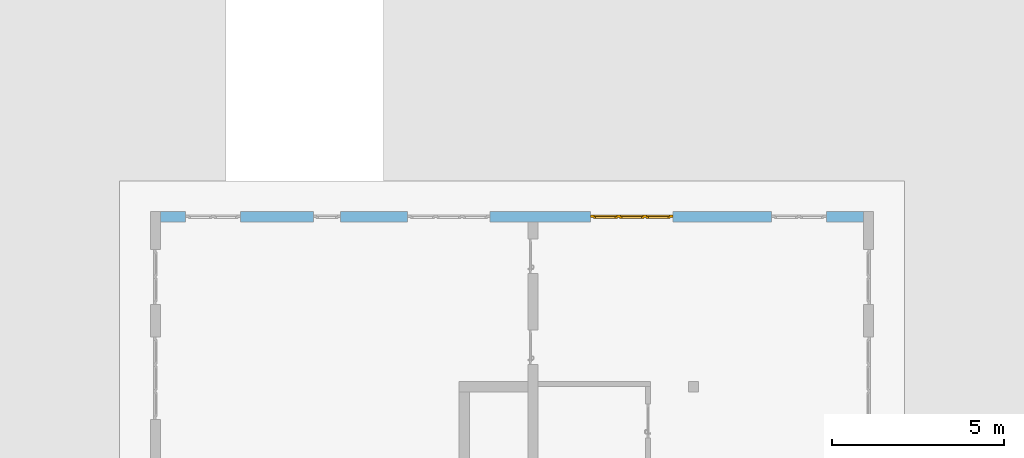
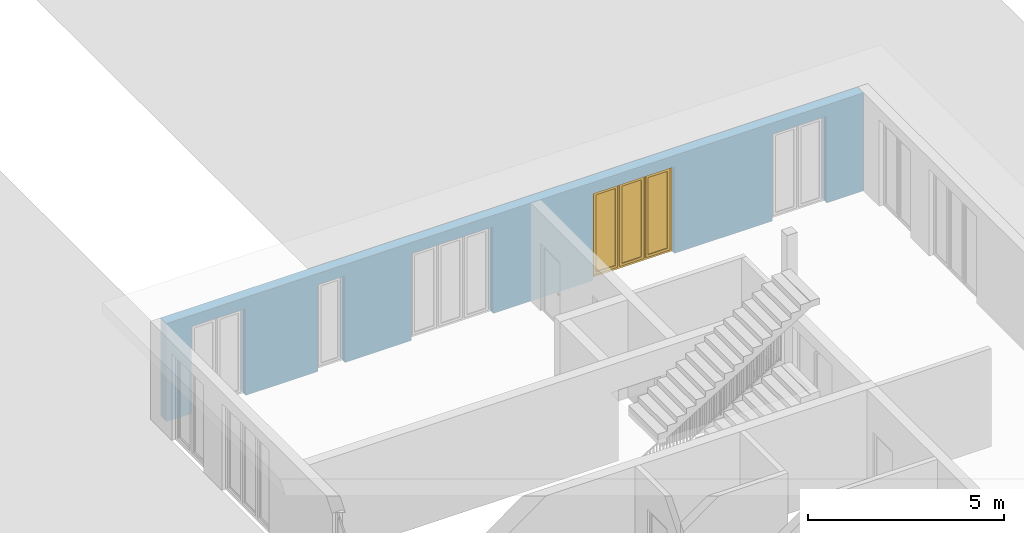
# One storey, part 17 of 23: 1 window, 5 openings, plus 1 element that does not belong to this part.
"""IFC4 building model written with IfcOpenShell, lengths in metres."""

from ifc_helpers import new_model, entity, si_unit, converted_unit, derived_unit, direction, frame, origin_with_axes, place, context, subcontext, project, spatial, polygons, source, transform, mapped, material, type_object, element, fill, save


model = new_model("IFC4")

# Units and contexts
model_context = context("Model", 3, precision=1e-05, world=origin_with_axes(), true_north=direction((0.0, 1.0)))
body_context = subcontext(model_context, "Body", "Model", "MODEL_VIEW")
ifc_project = project(units=[si_unit("LENGTHUNIT", "METRE"), si_unit("AREAUNIT", "SQUARE_METRE"), si_unit("VOLUMEUNIT", "CUBIC_METRE"), converted_unit("PLANEANGLEUNIT", "DEGREE", entity("IfcPlaneAngleMeasure", 0.0174532925199), si_unit("PLANEANGLEUNIT", "RADIAN"), dimensions=[0, 0, 0, 0, 0, 0, 0]), converted_unit("TIMEUNIT", "Year", entity("IfcTimeMeasure", 31556926.0), si_unit("TIMEUNIT", "SECOND"), dimensions=[0, 0, 1, 0, 0, 0, 0]), si_unit("MASSUNIT", "GRAM", prefix="KILO"), si_unit("THERMODYNAMICTEMPERATUREUNIT", "DEGREE_CELSIUS"), si_unit("LUMINOUSINTENSITYUNIT", "LUMEN"), si_unit("ENERGYUNIT", "JOULE", prefix="MEGA"), derived_unit("THERMALCONDUCTANCEUNIT", [(si_unit("POWERUNIT", "WATT"), 1), (si_unit("LENGTHUNIT", "METRE"), -1), (si_unit("THERMODYNAMICTEMPERATUREUNIT", "KELVIN"), -1)]), derived_unit("SPECIFICHEATCAPACITYUNIT", [(si_unit("ENERGYUNIT", "JOULE"), 1), (si_unit("MASSUNIT", "GRAM", prefix="KILO"), -1), (si_unit("THERMODYNAMICTEMPERATUREUNIT", "KELVIN"), -1)]), derived_unit("MASSDENSITYUNIT", [(si_unit("MASSUNIT", "GRAM", prefix="KILO"), 1), (si_unit("VOLUMEUNIT", "CUBIC_METRE"), -1)])], contexts=[model_context])

# Site, building, storey
site_placement = place(None, origin_with_axes())
site = spatial("IfcSite", under=ifc_project, at=site_placement, CompositionType="ELEMENT")
building_placement = place(site_placement, origin_with_axes())
building = spatial("IfcBuilding", under=site, at=building_placement, CompositionType="ELEMENT")
storey_placement = place(building_placement, origin_with_axes())
storey = spatial("IfcBuildingStorey", under=building, at=storey_placement, Name="0. Geschoss", CompositionType="ELEMENT", Elevation=0.0)

# Wall, openings, window
ifc_material = material()
wall_type = type_object("IfcWallType", Name="300", PredefinedType="NOTDEFINED")
wall_placement = place(storey_placement, frame((-11.7421993804, 8.92118776896, 0.0), z_axis=(0.0, 0.0, 1.0), x_axis=(1.0, 0.0, 0.0)))
wall = element("IfcWall", 1, at=wall_placement, inside=storey, type_object=wall_type, material=ifc_material, Name="Wand-001", PredefinedType="NOTDEFINED", context=body_context, shape_type="Tessellation", body=[
    polygons([(15.23, -0.1, 0.0), (15.23, -0.3, 0.0), (15.23, -0.3, 2.7), (15.23, 0.0, 2.7), (15.23, 0.0, 0.0), (18.102139809, 0.0, 0.0), (18.102139809, -0.3, 0.0), (18.102139809, -0.3, 2.7), (19.702139809, -0.3, 2.7), (19.702139809, -0.3, 0.0), (20.78, -0.3, 0.0), (20.78, -0.3, 3.05), (0.3, -0.3, 3.05), (0.3, -0.3, 0.0), (1.0288518641, -0.3, 0.0), (1.0288518641, -0.3, 2.7), (2.6288518641, -0.3, 2.7), (2.6288518641, -0.3, 0.0), (4.75, -0.3, 0.0), (4.75, -0.3, 2.7), (5.55, -0.3, 2.7), (5.55, -0.3, 0.0), (7.50089858046, -0.3, 0.0), (7.50089858046, -0.3, 2.7), (9.90089858046, -0.3, 2.7), (9.90089858046, -0.3, 0.0), (12.83, -0.3, 0.0), (12.83, -0.3, 2.7), (12.83, 0.0, 2.7), (12.83, 0.0, 0.0), (9.90089858046, 0.0, 0.0), (9.90089858046, 0.0, 2.7), (7.50089858046, 0.0, 2.7), (7.50089858046, 0.0, 0.0), (5.55, 0.0, 0.0), (5.55, 0.0, 2.7), (4.75, 0.0, 2.7), (4.75, 0.0, 0.0), (2.6288518641, 0.0, 0.0), (2.6288518641, 0.0, 2.7), (1.0288518641, 0.0, 2.7), (1.0288518641, 0.0, 0.0), (0.3, 0.0, 0.0), (0.3, 0.0, 3.05), (20.78, 0.0, 3.05), (20.78, 0.0, 0.0), (19.702139809, 0.0, 0.0), (19.702139809, 0.0, 2.7), (18.102139809, 0.0, 2.7), (12.83, -0.1, 0.0)], [[[1, 2, 3, 4, 5]], [[2, 1, 5, 6, 7]], [[3, 2, 7, 8, 9, 10, 11, 12, 13, 14, 15, 16, 17, 18, 19, 20, 21, 22, 23, 24, 25, 26, 27, 28]], [[4, 3, 28, 29]], [[6, 5, 4, 29, 30, 31, 32, 33, 34, 35, 36, 37, 38, 39, 40, 41, 42, 43, 44, 45, 46, 47, 48, 49]], [[6, 49, 8, 7]], [[8, 49, 48, 9]], [[48, 47, 10, 9]], [[46, 11, 10, 47]], [[12, 11, 46, 45]], [[45, 44, 13, 12]], [[44, 43, 14, 13]], [[15, 14, 43, 42]], [[16, 15, 42, 41]], [[40, 17, 16, 41]], [[18, 17, 40, 39]], [[19, 18, 39, 38]], [[20, 19, 38, 37]], [[36, 21, 20, 37]], [[22, 21, 36, 35]], [[22, 35, 34, 23]], [[34, 33, 24, 23]], [[24, 33, 32, 25]], [[32, 31, 26, 25]], [[50, 27, 26, 31, 30]], [[28, 27, 50, 30, 29]]], closed=True),
])
opening_1_placement = place(wall_placement, frame((1.8288518641, 0.0, 0.0), z_axis=(0.0, 0.0, 1.0), x_axis=(1.0, 0.0, 0.0)))
element("IfcOpeningElement", 2, at=opening_1_placement, cuts=wall, Name="Fenster-001", context=body_context, identifier="Reference", shape_type="Tessellation", body=[
    polygons([(-0.8, -0.1, 0.0), (-0.8, -0.1, 2.7), (-0.8, 0.000999999999998, 2.7), (-0.8, 0.000999999999998, 0.0), (-0.8, -0.301, 0.0), (-0.8, -0.301, 2.7), (0.8, -0.1, 2.7), (0.8, 0.000999999999999, 2.7), (0.8, -0.301, 2.7), (0.8, 0.000999999999999, 0.0), (0.8, -0.1, 0.0), (0.8, -0.301, 0.0)], [[[1, 2, 3, 4]], [[2, 1, 5, 6]], [[7, 8, 3, 2, 6, 9]], [[8, 10, 4, 3]], [[1, 4, 10, 11, 12, 5]], [[6, 5, 12, 9]], [[7, 11, 10, 8]], [[11, 7, 9, 12]]], closed=True),
])
opening_2_placement = place(wall_placement, frame((8.70089858046, 0.0, 0.0), z_axis=(0.0, 0.0, 1.0), x_axis=(1.0, 0.0, 0.0)))
element("IfcOpeningElement", 3, at=opening_2_placement, cuts=wall, Name="Fenster-002", context=body_context, identifier="Reference", shape_type="Tessellation", body=[
    polygons([(-1.2, -0.1, 0.0), (-1.2, -0.1, 2.7), (-1.2, 0.000999999999999, 2.7), (-1.2, 0.000999999999999, 0.0), (-1.2, -0.301, 0.0), (-1.2, -0.301, 2.7), (1.2, -0.1, 2.7), (1.2, 0.001, 2.7), (1.2, -0.301, 2.7), (1.2, 0.001, 0.0), (1.2, -0.1, 0.0), (1.2, -0.301, 0.0)], [[[1, 2, 3, 4]], [[2, 1, 5, 6]], [[7, 8, 3, 2, 6, 9]], [[8, 10, 4, 3]], [[1, 4, 10, 11, 12, 5]], [[6, 5, 12, 9]], [[7, 11, 10, 8]], [[11, 7, 9, 12]]], closed=True),
])
opening_3_placement = place(wall_placement, frame((5.15, 0.0, 0.0), z_axis=(0.0, 0.0, 1.0), x_axis=(1.0, 0.0, 0.0)))
element("IfcOpeningElement", 4, at=opening_3_placement, cuts=wall, Name="Fenster-003", context=body_context, identifier="Reference", shape_type="Tessellation", body=[
    polygons([(-0.4, -0.1, 0.0), (-0.4, -0.1, 2.7), (-0.4, 0.001, 2.7), (-0.4, 0.001, 0.0), (-0.4, -0.301, 0.0), (-0.4, -0.301, 2.7), (0.4, -0.1, 2.7), (0.4, 0.001, 2.7), (0.4, -0.301, 2.7), (0.4, 0.001, 0.0), (0.4, -0.1, 0.0), (0.4, -0.301, 0.0)], [[[1, 2, 3, 4]], [[2, 1, 5, 6]], [[7, 8, 3, 2, 6, 9]], [[8, 10, 4, 3]], [[1, 4, 10, 11, 12, 5]], [[6, 5, 12, 9]], [[7, 11, 10, 8]], [[11, 7, 9, 12]]], closed=True),
])
opening_4_placement = place(wall_placement, frame((18.902139809, 0.0, 0.0), z_axis=(0.0, 0.0, 1.0), x_axis=(1.0, 0.0, 0.0)))
element("IfcOpeningElement", 5, at=opening_4_placement, cuts=wall, Name="Fenster-001", context=body_context, identifier="Reference", shape_type="Tessellation", body=[
    polygons([(-0.8, -0.1, 0.0), (-0.8, -0.1, 2.7), (-0.8, 0.001, 2.7), (-0.8, 0.001, 0.0), (-0.8, -0.301, 0.0), (-0.8, -0.301, 2.7), (0.8, -0.1, 2.7), (0.8, 0.001, 2.7), (0.8, -0.301, 2.7), (0.8, 0.001, 0.0), (0.8, -0.1, 0.0), (0.8, -0.301, 0.0)], [[[1, 2, 3, 4]], [[2, 1, 5, 6]], [[7, 8, 3, 2, 6, 9]], [[8, 10, 4, 3]], [[1, 4, 10, 11, 12, 5]], [[6, 5, 12, 9]], [[7, 11, 10, 8]], [[11, 7, 9, 12]]], closed=True),
])
opening_5_placement = place(wall_placement, frame((14.03, 0.0, 0.0), z_axis=(0.0, 0.0, 1.0), x_axis=(1.0, 0.0, 0.0)))
opening_5 = element("IfcOpeningElement", 6, at=opening_5_placement, cuts=wall, Name="Fenster-002", context=body_context, identifier="Reference", shape_type="Tessellation", body=[
    polygons([(-1.2, -0.1, 0.0), (-1.2, -0.1, 2.7), (-1.2, 0.001, 2.7), (-1.2, 0.001, 0.0), (-1.2, -0.301, 0.0), (-1.2, -0.301, 2.7), (1.2, -0.1, 2.7), (1.2, 0.001, 2.7), (1.2, -0.301, 2.7), (1.2, 0.001, 0.0), (1.2, -0.1, 0.0), (1.2, -0.301, 0.0)], [[[1, 2, 3, 4]], [[2, 1, 5, 6]], [[7, 8, 3, 2, 6, 9]], [[8, 10, 4, 3]], [[1, 4, 10, 11, 12, 5]], [[6, 5, 12, 9]], [[7, 11, 10, 8]], [[11, 7, 9, 12]]], closed=True),
])
window_type = type_object("IfcWindowType", Name="3-1+1+1 26", PartitioningType="TRIPLE_PANEL_VERTICAL", PredefinedType="WINDOW")
shared_shape = source(origin_with_axes(), body_context, "Body", "Tessellation", [
    polygons([(-1.2, -0.07, 0.0), (-1.2, 0.0, 0.0), (-1.1, 0.0, 0.1), (-1.1, -0.07, 0.1), (-1.2, -0.07, 2.7), (-1.2, 0.0, 2.7), (-1.1, 0.0, 2.6), (-1.1, -0.07, 2.6)], [[[1, 2, 3, 4]], [[5, 6, 2, 1]], [[2, 6, 7, 3]], [[4, 3, 7, 8]], [[1, 4, 8, 5]], [[8, 7, 6, 5]]], closed=True),
    polygons([(1.2, -0.07, 0.0), (1.2, 0.0, 0.0), (1.2, 0.0, 2.7), (1.2, -0.07, 2.7), (1.1, -0.07, 0.1), (1.1, 0.0, 0.1), (1.1, 0.0, 2.6), (1.1, -0.07, 2.6)], [[[1, 2, 3, 4]], [[5, 6, 2, 1]], [[2, 6, 7, 3]], [[4, 3, 7, 8]], [[1, 4, 8, 5]], [[8, 7, 6, 5]]], closed=True),
    polygons([(-1.2, -0.07, 0.0), (-1.2, 0.0, 0.0), (1.2, 0.0, 0.0), (1.2, -0.07, 0.0), (-1.1, -0.07, 0.1), (-1.1, 0.0, 0.1), (-0.433333333333, 0.0, 0.1), (-0.333333333333, 0.0, 0.1), (0.333333333333, 0.0, 0.1), (0.433333333333, 0.0, 0.1), (1.1, 0.0, 0.1), (1.1, -0.07, 0.1), (0.433333333333, -0.07, 0.1), (0.333333333333, -0.07, 0.1), (-0.333333333333, -0.07, 0.1), (-0.433333333333, -0.07, 0.1)], [[[1, 2, 3, 4]], [[5, 6, 2, 1]], [[2, 6, 7, 8, 9, 10, 11, 3]], [[4, 3, 11, 12]], [[1, 4, 12, 13, 14, 15, 16, 5]], [[16, 7, 6, 5]], [[15, 8, 7, 16]], [[14, 9, 8, 15]], [[13, 10, 9, 14]], [[12, 11, 10, 13]]], closed=True),
    polygons([(-1.2, -0.07, 2.7), (-1.2, 0.0, 2.7), (-1.1, 0.0, 2.6), (-1.1, -0.07, 2.6), (1.2, -0.07, 2.7), (1.2, 0.0, 2.7), (1.1, 0.0, 2.6), (0.433333333333, 0.0, 2.6), (0.333333333333, 0.0, 2.6), (-0.333333333333, 0.0, 2.6), (-0.433333333333, 0.0, 2.6), (-0.433333333333, -0.07, 2.6), (-0.333333333333, -0.07, 2.6), (0.333333333333, -0.07, 2.6), (0.433333333333, -0.07, 2.6), (1.1, -0.07, 2.6)], [[[1, 2, 3, 4]], [[5, 6, 2, 1]], [[2, 6, 7, 8, 9, 10, 11, 3]], [[4, 3, 11, 12]], [[1, 4, 12, 13, 14, 15, 16, 5]], [[16, 7, 6, 5]], [[15, 8, 7, 16]], [[14, 9, 8, 15]], [[13, 10, 9, 14]], [[12, 11, 10, 13]]], closed=True),
    polygons([(0.333333333333, -0.07, 0.1), (0.333333333333, 0.0, 0.1), (0.433333333333, 0.0, 0.1), (0.433333333333, -0.07, 0.1), (0.333333333333, -0.07, 2.6), (0.333333333333, 0.0, 2.6), (0.433333333333, 0.0, 2.6), (0.433333333333, -0.07, 2.6)], [[[1, 2, 3, 4]], [[5, 6, 2, 1]], [[2, 6, 7, 3]], [[4, 3, 7, 8]], [[1, 4, 8, 5]], [[8, 7, 6, 5]]], closed=True),
    polygons([(-0.433333333333, -0.07, 0.1), (-0.433333333333, 0.0, 0.1), (-0.333333333333, 0.0, 0.1), (-0.333333333333, -0.07, 0.1), (-0.433333333333, -0.07, 2.6), (-0.433333333333, 0.0, 2.6), (-0.333333333333, 0.0, 2.6), (-0.333333333333, -0.07, 2.6)], [[[1, 2, 3, 4]], [[5, 6, 2, 1]], [[2, 6, 7, 3]], [[4, 3, 7, 8]], [[1, 4, 8, 5]], [[8, 7, 6, 5]]], closed=True),
    polygons([(-1.12, 0.0, 0.08), (-1.12, 0.03, 0.08), (-1.05, 0.03, 0.15), (-1.05, 0.0, 0.15), (-1.12, 0.0, 2.62), (-1.12, 0.03, 2.62), (-1.05, 0.03, 2.55), (-1.05, 0.0, 2.55)], [[[1, 2, 3, 4]], [[5, 6, 2, 1]], [[2, 6, 7, 3]], [[4, 3, 7, 8]], [[1, 4, 8, 5]], [[8, 7, 6, 5]]], closed=True),
    polygons([(-0.413333333333, 0.0, 0.08), (-0.483333333333, 0.0, 0.15), (-0.483333333333, 0.03, 0.15), (-0.413333333333, 0.03, 0.08), (-0.413333333333, 0.0, 2.62), (-0.483333333333, 0.0, 2.55), (-0.483333333333, 0.03, 2.55), (-0.413333333333, 0.03, 2.62)], [[[1, 2, 3, 4]], [[1, 5, 6, 2]], [[2, 6, 7, 3]], [[4, 3, 7, 8]], [[5, 1, 4, 8]], [[6, 5, 8, 7]]], closed=True),
    polygons([(-1.12, 0.0, 0.08), (-1.12, 0.03, 0.08), (-0.413333333333, 0.03, 0.08), (-0.413333333333, 0.0, 0.08), (-1.05, 0.0, 0.15), (-1.05, 0.03, 0.15), (-0.483333333333, 0.03, 0.15), (-0.483333333333, 0.0, 0.15)], [[[1, 2, 3, 4]], [[5, 6, 2, 1]], [[2, 6, 7, 3]], [[4, 3, 7, 8]], [[1, 4, 8, 5]], [[8, 7, 6, 5]]], closed=True),
    polygons([(-1.12, 0.0, 2.62), (-0.413333333333, 0.0, 2.62), (-0.413333333333, 0.03, 2.62), (-1.12, 0.03, 2.62), (-1.05, 0.0, 2.55), (-0.483333333333, 0.0, 2.55), (-0.483333333333, 0.03, 2.55), (-1.05, 0.03, 2.55)], [[[1, 2, 3, 4]], [[1, 5, 6, 2]], [[2, 6, 7, 3]], [[4, 3, 7, 8]], [[5, 1, 4, 8]], [[6, 5, 8, 7]]], closed=True),
    polygons([(-1.1, -0.03, 0.1), (-1.1, 0.0, 0.1), (-1.05, 0.0, 0.15), (-1.05, -0.03, 0.15), (-1.1, -0.03, 2.6), (-1.1, 0.0, 2.6), (-1.05, 0.0, 2.55), (-1.05, -0.03, 2.55)], [[[1, 2, 3, 4]], [[5, 6, 2, 1]], [[2, 6, 7, 3]], [[4, 3, 7, 8]], [[1, 4, 8, 5]], [[8, 7, 6, 5]]], closed=True),
    polygons([(-0.433333333333, -0.03, 0.1), (-0.483333333333, -0.03, 0.15), (-0.483333333333, 0.0, 0.15), (-0.433333333333, 0.0, 0.1), (-0.433333333333, -0.03, 2.6), (-0.483333333333, -0.03, 2.55), (-0.483333333333, 0.0, 2.55), (-0.433333333333, 0.0, 2.6)], [[[1, 2, 3, 4]], [[1, 5, 6, 2]], [[2, 6, 7, 3]], [[4, 3, 7, 8]], [[5, 1, 4, 8]], [[6, 5, 8, 7]]], closed=True),
    polygons([(-1.1, -0.03, 0.1), (-1.1, 0.0, 0.1), (-0.433333333333, 0.0, 0.1), (-0.433333333333, -0.03, 0.1), (-1.05, -0.03, 0.15), (-1.05, 0.0, 0.15), (-0.483333333333, 0.0, 0.15), (-0.483333333333, -0.03, 0.15)], [[[1, 2, 3, 4]], [[5, 6, 2, 1]], [[2, 6, 7, 3]], [[4, 3, 7, 8]], [[1, 4, 8, 5]], [[8, 7, 6, 5]]], closed=True),
    polygons([(-1.1, -0.03, 2.6), (-0.433333333333, -0.03, 2.6), (-0.433333333333, 0.0, 2.6), (-1.1, 0.0, 2.6), (-1.05, -0.03, 2.55), (-0.483333333333, -0.03, 2.55), (-0.483333333333, 0.0, 2.55), (-1.05, 0.0, 2.55)], [[[1, 2, 3, 4]], [[1, 5, 6, 2]], [[2, 6, 7, 3]], [[4, 3, 7, 8]], [[5, 1, 4, 8]], [[6, 5, 8, 7]]], closed=True),
    polygons([(-1.05, -0.005, 0.15), (-1.05, 0.005, 0.15), (-0.483333333333, 0.005, 0.15), (-0.483333333333, -0.005, 0.15), (-1.05, -0.005, 2.55), (-1.05, 0.005, 2.55), (-0.483333333333, 0.005, 2.55), (-0.483333333333, -0.005, 2.55)], [[[1, 2, 3, 4]], [[5, 6, 2, 1]], [[2, 6, 7, 3]], [[4, 3, 7, 8]], [[1, 4, 8, 5]], [[8, 7, 6, 5]]], closed=True),
    polygons([(-0.353333333333, 0.0, 0.08), (-0.353333333333, 0.03, 0.08), (-0.283333333333, 0.03, 0.15), (-0.283333333333, 0.0, 0.15), (-0.353333333333, 0.0, 2.62), (-0.353333333333, 0.03, 2.62), (-0.283333333333, 0.03, 2.55), (-0.283333333333, 0.0, 2.55)], [[[1, 2, 3, 4]], [[5, 6, 2, 1]], [[2, 6, 7, 3]], [[4, 3, 7, 8]], [[1, 4, 8, 5]], [[8, 7, 6, 5]]], closed=True),
    polygons([(0.353333333333, 0.0, 0.08), (0.283333333333, 0.0, 0.15), (0.283333333333, 0.03, 0.15), (0.353333333333, 0.03, 0.08), (0.353333333333, 0.0, 2.62), (0.283333333333, 0.0, 2.55), (0.283333333333, 0.03, 2.55), (0.353333333333, 0.03, 2.62)], [[[1, 2, 3, 4]], [[1, 5, 6, 2]], [[2, 6, 7, 3]], [[4, 3, 7, 8]], [[5, 1, 4, 8]], [[6, 5, 8, 7]]], closed=True),
    polygons([(-0.353333333333, 0.0, 0.08), (-0.353333333333, 0.03, 0.08), (0.353333333333, 0.03, 0.08), (0.353333333333, 0.0, 0.08), (-0.283333333333, 0.0, 0.15), (-0.283333333333, 0.03, 0.15), (0.283333333333, 0.03, 0.15), (0.283333333333, 0.0, 0.15)], [[[1, 2, 3, 4]], [[5, 6, 2, 1]], [[2, 6, 7, 3]], [[4, 3, 7, 8]], [[1, 4, 8, 5]], [[8, 7, 6, 5]]], closed=True),
    polygons([(-0.353333333333, 0.0, 2.62), (0.353333333333, 0.0, 2.62), (0.353333333333, 0.03, 2.62), (-0.353333333333, 0.03, 2.62), (-0.283333333333, 0.0, 2.55), (0.283333333333, 0.0, 2.55), (0.283333333333, 0.03, 2.55), (-0.283333333333, 0.03, 2.55)], [[[1, 2, 3, 4]], [[1, 5, 6, 2]], [[2, 6, 7, 3]], [[4, 3, 7, 8]], [[5, 1, 4, 8]], [[6, 5, 8, 7]]], closed=True),
    polygons([(-0.333333333333, -0.03, 0.1), (-0.333333333333, 0.0, 0.1), (-0.283333333333, 0.0, 0.15), (-0.283333333333, -0.03, 0.15), (-0.333333333333, -0.03, 2.6), (-0.333333333333, 0.0, 2.6), (-0.283333333333, 0.0, 2.55), (-0.283333333333, -0.03, 2.55)], [[[1, 2, 3, 4]], [[5, 6, 2, 1]], [[2, 6, 7, 3]], [[4, 3, 7, 8]], [[1, 4, 8, 5]], [[8, 7, 6, 5]]], closed=True),
    polygons([(0.333333333333, -0.03, 0.1), (0.283333333333, -0.03, 0.15), (0.283333333333, 0.0, 0.15), (0.333333333333, 0.0, 0.1), (0.333333333333, -0.03, 2.6), (0.283333333333, -0.03, 2.55), (0.283333333333, 0.0, 2.55), (0.333333333333, 0.0, 2.6)], [[[1, 2, 3, 4]], [[1, 5, 6, 2]], [[2, 6, 7, 3]], [[4, 3, 7, 8]], [[5, 1, 4, 8]], [[6, 5, 8, 7]]], closed=True),
    polygons([(-0.333333333333, -0.03, 0.1), (-0.333333333333, 0.0, 0.1), (0.333333333333, 0.0, 0.1), (0.333333333333, -0.03, 0.1), (-0.283333333333, -0.03, 0.15), (-0.283333333333, 0.0, 0.15), (0.283333333333, 0.0, 0.15), (0.283333333333, -0.03, 0.15)], [[[1, 2, 3, 4]], [[5, 6, 2, 1]], [[2, 6, 7, 3]], [[4, 3, 7, 8]], [[1, 4, 8, 5]], [[8, 7, 6, 5]]], closed=True),
    polygons([(-0.333333333333, -0.03, 2.6), (0.333333333333, -0.03, 2.6), (0.333333333333, 0.0, 2.6), (-0.333333333333, 0.0, 2.6), (-0.283333333333, -0.03, 2.55), (0.283333333333, -0.03, 2.55), (0.283333333333, 0.0, 2.55), (-0.283333333333, 0.0, 2.55)], [[[1, 2, 3, 4]], [[1, 5, 6, 2]], [[2, 6, 7, 3]], [[4, 3, 7, 8]], [[5, 1, 4, 8]], [[6, 5, 8, 7]]], closed=True),
    polygons([(-0.283333333333, -0.005, 0.15), (-0.283333333333, 0.005, 0.15), (0.283333333333, 0.005, 0.15), (0.283333333333, -0.005, 0.15), (-0.283333333333, -0.005, 2.55), (-0.283333333333, 0.005, 2.55), (0.283333333333, 0.005, 2.55), (0.283333333333, -0.005, 2.55)], [[[1, 2, 3, 4]], [[5, 6, 2, 1]], [[2, 6, 7, 3]], [[4, 3, 7, 8]], [[1, 4, 8, 5]], [[8, 7, 6, 5]]], closed=True),
    polygons([(0.413333333333, 0.0, 0.08), (0.413333333333, 0.03, 0.08), (0.483333333333, 0.03, 0.15), (0.483333333333, 0.0, 0.15), (0.413333333333, 0.0, 2.62), (0.413333333333, 0.03, 2.62), (0.483333333333, 0.03, 2.55), (0.483333333333, 0.0, 2.55)], [[[1, 2, 3, 4]], [[5, 6, 2, 1]], [[2, 6, 7, 3]], [[4, 3, 7, 8]], [[1, 4, 8, 5]], [[8, 7, 6, 5]]], closed=True),
    polygons([(1.12, 0.0, 0.08), (1.05, 0.0, 0.15), (1.05, 0.03, 0.15), (1.12, 0.03, 0.08), (1.12, 0.0, 2.62), (1.05, 0.0, 2.55), (1.05, 0.03, 2.55), (1.12, 0.03, 2.62)], [[[1, 2, 3, 4]], [[1, 5, 6, 2]], [[2, 6, 7, 3]], [[4, 3, 7, 8]], [[5, 1, 4, 8]], [[6, 5, 8, 7]]], closed=True),
    polygons([(0.413333333333, 0.0, 0.08), (0.413333333333, 0.03, 0.08), (1.12, 0.03, 0.08), (1.12, 0.0, 0.08), (0.483333333333, 0.0, 0.15), (0.483333333333, 0.03, 0.15), (1.05, 0.03, 0.15), (1.05, 0.0, 0.15)], [[[1, 2, 3, 4]], [[5, 6, 2, 1]], [[2, 6, 7, 3]], [[4, 3, 7, 8]], [[1, 4, 8, 5]], [[8, 7, 6, 5]]], closed=True),
    polygons([(0.413333333333, 0.0, 2.62), (1.12, 0.0, 2.62), (1.12, 0.03, 2.62), (0.413333333333, 0.03, 2.62), (0.483333333333, 0.0, 2.55), (1.05, 0.0, 2.55), (1.05, 0.03, 2.55), (0.483333333333, 0.03, 2.55)], [[[1, 2, 3, 4]], [[1, 5, 6, 2]], [[2, 6, 7, 3]], [[4, 3, 7, 8]], [[5, 1, 4, 8]], [[6, 5, 8, 7]]], closed=True),
    polygons([(0.433333333333, -0.03, 0.1), (0.433333333333, 0.0, 0.1), (0.483333333333, 0.0, 0.15), (0.483333333333, -0.03, 0.15), (0.433333333333, -0.03, 2.6), (0.433333333333, 0.0, 2.6), (0.483333333333, 0.0, 2.55), (0.483333333333, -0.03, 2.55)], [[[1, 2, 3, 4]], [[5, 6, 2, 1]], [[2, 6, 7, 3]], [[4, 3, 7, 8]], [[1, 4, 8, 5]], [[8, 7, 6, 5]]], closed=True),
    polygons([(1.1, -0.03, 0.1), (1.05, -0.03, 0.15), (1.05, 0.0, 0.15), (1.1, 0.0, 0.1), (1.1, -0.03, 2.6), (1.05, -0.03, 2.55), (1.05, 0.0, 2.55), (1.1, 0.0, 2.6)], [[[1, 2, 3, 4]], [[1, 5, 6, 2]], [[2, 6, 7, 3]], [[4, 3, 7, 8]], [[5, 1, 4, 8]], [[6, 5, 8, 7]]], closed=True),
    polygons([(0.433333333333, -0.03, 0.1), (0.433333333333, 0.0, 0.1), (1.1, 0.0, 0.1), (1.1, -0.03, 0.1), (0.483333333333, -0.03, 0.15), (0.483333333333, 0.0, 0.15), (1.05, 0.0, 0.15), (1.05, -0.03, 0.15)], [[[1, 2, 3, 4]], [[5, 6, 2, 1]], [[2, 6, 7, 3]], [[4, 3, 7, 8]], [[1, 4, 8, 5]], [[8, 7, 6, 5]]], closed=True),
    polygons([(0.433333333333, -0.03, 2.6), (1.1, -0.03, 2.6), (1.1, 0.0, 2.6), (0.433333333333, 0.0, 2.6), (0.483333333333, -0.03, 2.55), (1.05, -0.03, 2.55), (1.05, 0.0, 2.55), (0.483333333333, 0.0, 2.55)], [[[1, 2, 3, 4]], [[1, 5, 6, 2]], [[2, 6, 7, 3]], [[4, 3, 7, 8]], [[5, 1, 4, 8]], [[6, 5, 8, 7]]], closed=True),
    polygons([(0.483333333333, -0.005, 0.15), (0.483333333333, 0.005, 0.15), (1.05, 0.005, 0.15), (1.05, -0.005, 0.15), (0.483333333333, -0.005, 2.55), (0.483333333333, 0.005, 2.55), (1.05, 0.005, 2.55), (1.05, -0.005, 2.55)], [[[1, 2, 3, 4]], [[5, 6, 2, 1]], [[2, 6, 7, 3]], [[4, 3, 7, 8]], [[1, 4, 8, 5]], [[8, 7, 6, 5]]], closed=True),
])
window_placement = place(opening_5_placement, frame((1.2, 0.0, 0.0), z_axis=(0.0, 0.0, 1.0), x_axis=(-1.0, 0.0, 0.0)))
window = element("IfcWindow", 7, at=window_placement, inside=storey, type_object=window_type, Name="Fenster-002", OverallHeight=2.7, OverallWidth=2.4, PredefinedType="WINDOW", context=body_context, shape_type="MappedRepresentation", body=[
    mapped(shared_shape, transform((1.2, 0.17, 0.0))),
])
fill(opening_5, window)

save(model, "model.ifc")
